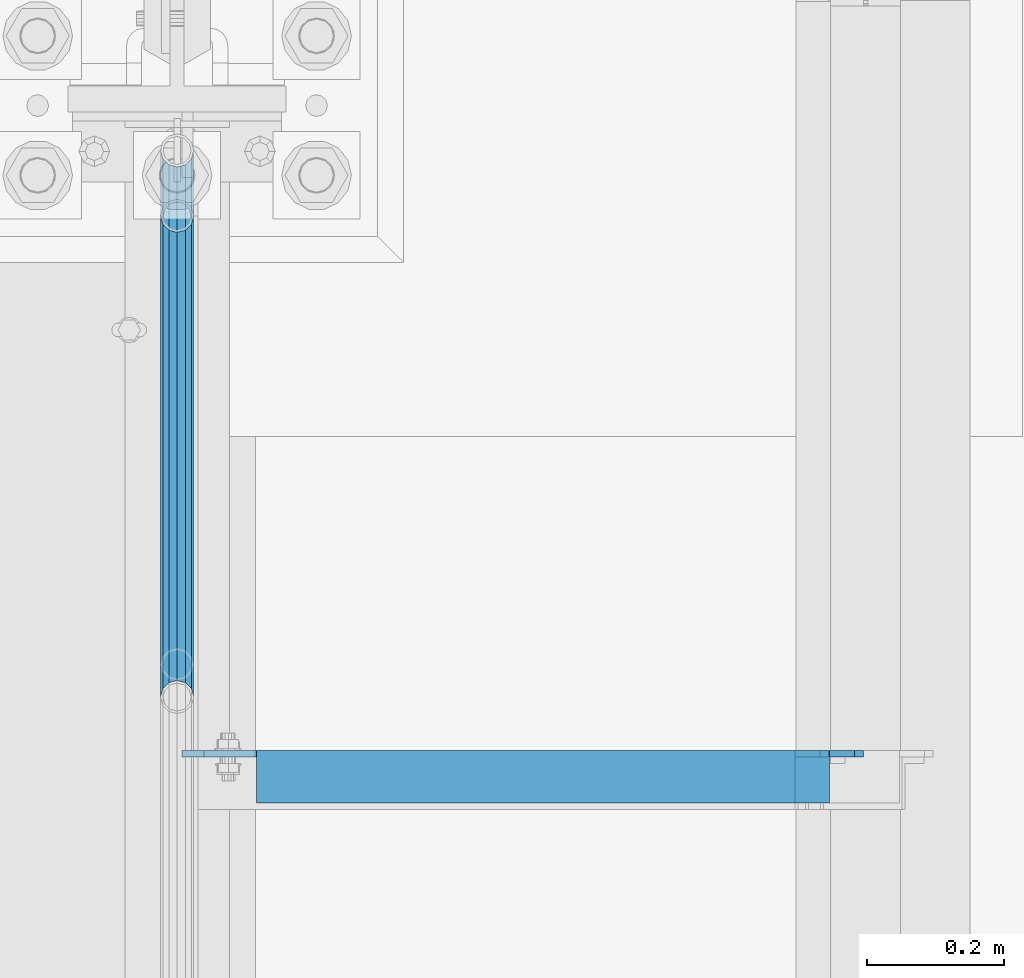
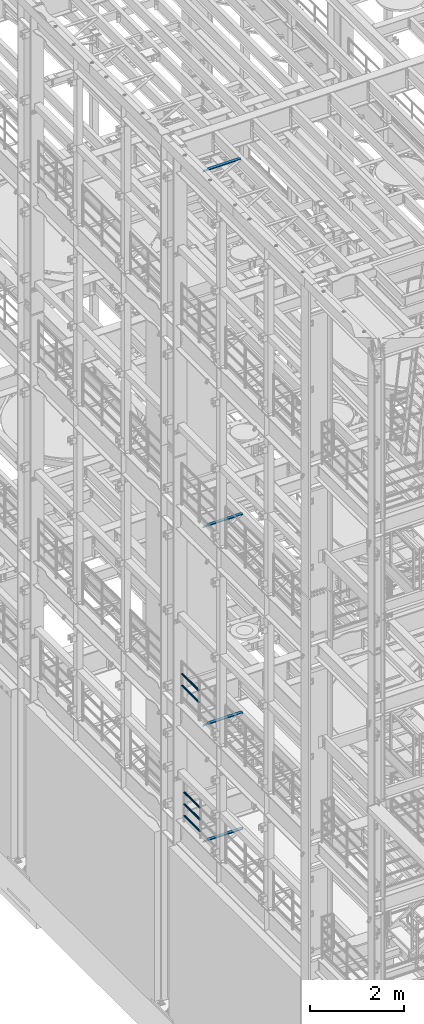
# One storey, part 1234 of 1876: 9 beams, 6 elements without a shape of their own.
"""IFC2X3 building model written with IfcOpenShell, lengths in millimetres."""

from ifc_helpers import new_model, si_unit, frame, origin_with_axes, place, context, subcontext, project, spatial, faceted_brep, material, type_object, element, aggregate, save


model = new_model("IFC2X3")

# Units and contexts
model_context = context("Model", 3, precision=1e-05, world=origin_with_axes())
body_context = subcontext(model_context, "Body", "Model", "MODEL_VIEW")
ifc_project = project(units=[si_unit("LENGTHUNIT", "METRE", prefix="MILLI"), si_unit("AREAUNIT", "SQUARE_METRE"), si_unit("VOLUMEUNIT", "CUBIC_METRE"), si_unit("MASSUNIT", "GRAM", prefix="KILO"), si_unit("TIMEUNIT", "SECOND"), si_unit("PLANEANGLEUNIT", "RADIAN"), si_unit("SOLIDANGLEUNIT", "STERADIAN"), si_unit("THERMODYNAMICTEMPERATUREUNIT", "DEGREE_CELSIUS"), si_unit("LUMINOUSINTENSITYUNIT", "LUMEN")], contexts=[model_context])

# Site, building, storey
site_placement = place(None, origin_with_axes())
site = spatial("IfcSite", under=ifc_project, at=site_placement, CompositionType="ELEMENT")
building_placement = place(site_placement, origin_with_axes())
building = spatial("IfcBuilding", under=site, at=building_placement, Name="Undefined", CompositionType="ELEMENT")
storey_placement = place(building_placement, origin_with_axes())
storey = spatial("IfcBuildingStorey", under=building, at=storey_placement, Name="Undefined", CompositionType="ELEMENT", Elevation=0.0)

# Assembly, beams
assembly_1_placement = place(storey_placement, origin_with_axes())
assembly_1 = element("IfcElementAssembly", 1, at=assembly_1_placement, inside=storey, Name="RAIL", AssemblyPlace="NOTDEFINED", PredefinedType="RIGID_FRAME")
ifc_material_1 = material()
beam_type_1 = type_object("IfcBeamType", Name="PIPE1-1/2SCH40", PredefinedType="NOTDEFINED")
beam_1_placement = place(assembly_1_placement, frame((-1.81898940354586e-12, 430.212499999999, 8620.125), z_axis=(0.0, 0.0, -1.0), x_axis=(0.0, 1.0, 0.0)))
beam_1 = element("IfcBeam", 2, at=beam_1_placement, type_object=beam_type_1, material=ifc_material_1, Name="RAIL", ObjectType="PIPE1-1/2SCH40", context=body_context, shape_type="Brep", body=[
    faceted_brep([(0.0, 24.1299999999992, 0.0), (12.0650000000064, 20.8971929933177, -12.0649999999987), (12.0650000000064, 20.8971929933177, 12.0649999999987), (12.0650000000064, -20.8971929933177, 12.0649999999987), (12.0650000000064, -20.8971929933177, -12.0649999999987), (0.0, -24.1299999999992, 0.0), (20.8971929933249, -12.0650000000005, 20.8971929933177), (20.8971929933249, -12.0650000000005, 15.8661214311796), (15.2545715621445, -17.7076214311801, 10.2235000000001), (12.5151929933249, -20.4470000000001, 0.0), (15.2545715621445, -17.7076214311801, -10.2235000000001), (20.8971929933249, -12.0650000000005, -15.8661214311796), (20.8971929933249, -12.0650000000005, -20.8971929933177), (24.1300000000063, 0.0, -20.4470000000001), (24.1300000000063, 0.0, -24.130000000001), (21.3906214311868, -10.2235000000001, -17.7076214311819), (21.3906214311868, 10.2235000000001, -17.7076214311819), (20.8971929933249, 12.0650000000005, -15.8661214311796), (20.8971929933249, 12.0650000000005, -20.8971929933177), (15.2545715621445, 17.7076214311801, -10.2235000000001), (12.5151929933249, 20.4470000000001, 0.0), (15.2545715621445, 17.7076214311801, 10.2235000000001), (20.8971929933249, 12.0650000000005, 15.8661214311796), (20.8971929933249, 12.0650000000005, 20.8971929933177), (21.3906214311868, 10.2235000000001, 17.7076214311819), (24.1300000000064, 0.0, 20.4470000000001), (24.1300000000064, 0.0, 24.130000000001), (21.3906214311868, -10.2235000000001, 17.7076214311819), (748.982500000002, 24.1300000000001, 0.0), (736.917500000002, 20.8971929933186, -12.0649999999987), (728.085307006683, 12.0649999999996, -20.8971929933177), (748.982500000002, -24.1300000000001, 0.0), (736.917500000002, -20.8971929933186, -12.0649999999987), (736.917500000002, -20.8971929933186, 12.0649999999987), (728.085307006683, -12.0649999999996, 20.8971929933177), (728.085307006683, -12.0649999999996, -20.8971929933177), (724.852500000002, 0.0, -24.130000000001), (727.591878568821, 10.2235000000001, -17.7076214311819), (724.852500000002, 0.0, -20.4470000000001), (728.085307006683, 12.0649999999996, -15.8661214311796), (728.085307006683, -12.0649999999996, -15.8661214311796), (727.591878568821, -10.2235000000001, -17.7076214311819), (733.727928437864, -17.7076214311801, -10.2235000000001), (736.467307006683, -20.4470000000001, 0.0), (733.727928437864, -17.7076214311801, 10.2235000000001), (728.085307006683, -12.0649999999996, 15.8661214311796), (727.591878568821, -10.2235000000001, 17.7076214311819), (724.852500000002, 0.0, 20.4470000000001), (724.852500000002, 0.0, 24.130000000001), (728.085307006683, 12.0649999999996, 20.8971929933177), (736.917500000002, 20.8971929933186, 12.0649999999987), (728.085307006683, 12.0649999999996, 15.8661214311796), (733.727928437864, 17.7076214311801, 10.2235000000001), (736.467307006683, 20.4470000000001, 0.0), (733.727928437864, 17.7076214311801, -10.2235000000001), (727.591878568821, 10.2235000000001, 17.7076214311819)], [[[0, 1, 2]], [[3, 4, 5]], [[6, 7, 8, 9, 10, 11, 12, 4, 3]], [[13, 14, 12, 11, 15]], [[16, 17, 18, 14, 13]], [[2, 1, 18, 17, 19, 20, 21, 22, 23]], [[23, 22, 24, 25, 26]], [[26, 25, 27, 7, 6]], [[1, 0, 28, 29]], [[18, 1, 29, 30]], [[31, 32, 33]], [[6, 3, 33, 34]], [[3, 5, 31, 33]], [[5, 4, 32, 31]], [[4, 12, 35, 32]], [[12, 14, 36, 35]], [[14, 18, 30, 36]], [[37, 38, 36, 30, 39]], [[40, 35, 36, 38, 41]], [[33, 32, 35, 40, 42, 43, 44, 45, 34]], [[34, 45, 46, 47, 48]], [[26, 6, 34, 48]], [[2, 23, 49, 50]], [[23, 26, 48, 49]], [[0, 2, 50, 28]], [[28, 50, 29]], [[49, 51, 52, 53, 54, 39, 30, 29, 50]], [[48, 47, 55, 51, 49]], [[25, 24, 55, 47]], [[55, 24, 22, 21, 52, 51]], [[21, 20, 53, 52]], [[20, 19, 54, 53]], [[19, 17, 16, 37, 39, 54]], [[16, 13, 38, 37]], [[13, 15, 41, 38]], [[41, 15, 11, 10, 42, 40]], [[10, 9, 43, 42]], [[9, 8, 44, 43]], [[8, 7, 27, 46, 45, 44]], [[27, 25, 47, 46]]]),
])
beam_2_placement = place(assembly_1_placement, frame((-1.81898940354586e-12, 430.212499999999, 8924.925), z_axis=(0.0, 0.0, -1.0), x_axis=(0.0, 1.0, 0.0)))
beam_2 = element("IfcBeam", 3, at=beam_2_placement, type_object=beam_type_1, material=ifc_material_1, Name="RAIL", ObjectType="PIPE1-1/2SCH40", context=body_context, shape_type="Brep", body=[
    faceted_brep([(0.0, 24.1299999999992, 0.0), (12.0650000000064, 20.8971929933177, -12.0649999999987), (12.0650000000064, 20.8971929933177, 12.0649999999987), (12.0650000000064, -20.8971929933177, 12.0649999999987), (12.0650000000064, -20.8971929933177, -12.0649999999987), (0.0, -24.1299999999992, 0.0), (20.8971929933249, -12.0650000000005, 20.8971929933177), (20.8971929933249, -12.0650000000005, 15.8661214311796), (15.2545715621445, -17.7076214311801, 10.2235000000001), (12.5151929933249, -20.4470000000001, 0.0), (15.2545715621445, -17.7076214311801, -10.2235000000001), (20.8971929933249, -12.0650000000005, -15.8661214311796), (20.8971929933249, -12.0650000000005, -20.8971929933177), (24.1300000000063, 0.0, -20.4470000000001), (24.1300000000063, 0.0, -24.130000000001), (21.3906214311868, -10.2235000000001, -17.7076214311819), (21.3906214311868, 10.2235000000001, -17.7076214311819), (20.8971929933249, 12.0650000000005, -15.8661214311796), (20.8971929933249, 12.0650000000005, -20.8971929933177), (15.2545715621445, 17.7076214311801, -10.2235000000001), (12.5151929933249, 20.4470000000001, 0.0), (15.2545715621445, 17.7076214311801, 10.2235000000001), (20.8971929933249, 12.0650000000005, 15.8661214311796), (20.8971929933249, 12.0650000000005, 20.8971929933177), (21.3906214311868, 10.2235000000001, 17.7076214311819), (24.1300000000064, 0.0, 20.4470000000001), (24.1300000000064, 0.0, 24.130000000001), (21.3906214311868, -10.2235000000001, 17.7076214311819), (748.982500000002, 24.1300000000001, 0.0), (736.917500000002, 20.8971929933186, -12.0649999999987), (728.085307006683, 12.0649999999996, -20.8971929933177), (748.982500000002, -24.1300000000001, 0.0), (736.917500000002, -20.8971929933186, -12.0649999999987), (736.917500000002, -20.8971929933186, 12.0649999999987), (728.085307006683, -12.0649999999996, 20.8971929933177), (728.085307006683, -12.0649999999996, -20.8971929933177), (724.852500000002, 0.0, -24.130000000001), (727.591878568821, 10.2235000000001, -17.7076214311819), (724.852500000002, 0.0, -20.4470000000001), (728.085307006683, 12.0649999999996, -15.8661214311796), (728.085307006683, -12.0649999999996, -15.8661214311796), (727.591878568821, -10.2235000000001, -17.7076214311819), (733.727928437864, -17.7076214311801, -10.2235000000001), (736.467307006683, -20.4470000000001, 0.0), (733.727928437864, -17.7076214311801, 10.2235000000001), (728.085307006683, -12.0649999999996, 15.8661214311796), (727.591878568821, -10.2235000000001, 17.7076214311819), (724.852500000002, 0.0, 20.4470000000001), (724.852500000002, 0.0, 24.130000000001), (728.085307006683, 12.0649999999996, 20.8971929933177), (736.917500000002, 20.8971929933186, 12.0649999999987), (728.085307006683, 12.0649999999996, 15.8661214311796), (733.727928437864, 17.7076214311801, 10.2235000000001), (736.467307006683, 20.4470000000001, 0.0), (733.727928437864, 17.7076214311801, -10.2235000000001), (727.591878568821, 10.2235000000001, 17.7076214311819)], [[[0, 1, 2]], [[3, 4, 5]], [[6, 7, 8, 9, 10, 11, 12, 4, 3]], [[13, 14, 12, 11, 15]], [[16, 17, 18, 14, 13]], [[2, 1, 18, 17, 19, 20, 21, 22, 23]], [[23, 22, 24, 25, 26]], [[26, 25, 27, 7, 6]], [[1, 0, 28, 29]], [[18, 1, 29, 30]], [[31, 32, 33]], [[6, 3, 33, 34]], [[3, 5, 31, 33]], [[5, 4, 32, 31]], [[4, 12, 35, 32]], [[12, 14, 36, 35]], [[14, 18, 30, 36]], [[37, 38, 36, 30, 39]], [[40, 35, 36, 38, 41]], [[33, 32, 35, 40, 42, 43, 44, 45, 34]], [[34, 45, 46, 47, 48]], [[26, 6, 34, 48]], [[2, 23, 49, 50]], [[23, 26, 48, 49]], [[0, 2, 50, 28]], [[28, 50, 29]], [[49, 51, 52, 53, 54, 39, 30, 29, 50]], [[48, 47, 55, 51, 49]], [[25, 24, 55, 47]], [[55, 24, 22, 21, 52, 51]], [[21, 20, 53, 52]], [[20, 19, 54, 53]], [[19, 17, 16, 37, 39, 54]], [[16, 13, 38, 37]], [[13, 15, 41, 38]], [[41, 15, 11, 10, 42, 40]], [[10, 9, 43, 42]], [[9, 8, 44, 43]], [[8, 7, 27, 46, 45, 44]], [[27, 25, 47, 46]]]),
])
aggregate(assembly_1, [beam_1, beam_2])

assembly_2_placement = place(storey_placement, origin_with_axes())
assembly_2 = element("IfcElementAssembly", 4, at=assembly_2_placement, inside=storey, Name="RAIL", AssemblyPlace="NOTDEFINED", PredefinedType="RIGID_FRAME")
beam_3_placement = place(assembly_2_placement, frame((7.02584657119587e-11, 382.569831680701, 5292.73091229414), z_axis=(0.0, -8.42999999986204e-06, 0.999999999964468), x_axis=(0.0, 0.999999999964468, 8.43000000018809e-06)))
beam_3 = element("IfcBeam", 5, at=beam_3_placement, type_object=beam_type_1, material=ifc_material_1, Name="RAIL", ObjectType="PIPE1-1/2SCH40", context=body_context, shape_type="Brep", body=[
    faceted_brep([(680.442814874983, -12.0649999999996, 20.8971929933068), (680.44277246305, -12.0649999999277, 15.8661214312397), (679.949359549034, -10.2235000000001, 17.7076214311674), (677.210004073059, 2.72848410531878e-12, 20.4469999999883), (677.210035120749, 2.72848410531878e-12, 24.1299999999883), (679.949359548996, 10.2235000000001, 17.7076214311674), (680.44277246305, 12.0650000000714, 15.866121431096), (680.442814874983, 12.0649999999996, 20.8971929933068), (701.33983170571, 24.1300000000001, -1.45519152283669e-11), (689.27493341323, 20.8971929933186, 12.0649999999878), (689.27472999733, 20.8971929933186, -12.0650000000151), (686.085346327061, 17.7076214311801, 10.2234999999873), (688.824638711873, 20.4470000000001, -1.36424205265939e-11), (686.085173958852, 17.7076214311801, -10.2235000000137), (680.442504960242, 12.0650000000714, -15.8661214311223), (680.442462548309, 12.0649999999996, -20.8971929933323), (679.949060998498, 10.2235000000001, -17.7076214311946), (677.20965933664, 0.0, -20.4470000000147), (677.20962828895, 0.0, -24.1300000000147), (680.442504960242, -12.0649999999277, -15.866121431266), (680.442462548309, -12.0649999999996, -20.8971929933323), (679.949060998536, -10.2235000000001, -17.7076214311946), (701.33983170571, -24.1299999999283, -1.45519152283669e-11), (689.27472999733, -20.8971929933186, -12.0650000000151), (689.27493341323, -20.8971929933186, 12.0649999999878), (686.085173958994, -17.7076214311801, -10.2235000000137), (688.824638712016, -20.4470000000001, -1.36424205265939e-11), (686.085346327204, -17.7076214311801, 10.2234999999873), (12.0648982924813, -20.8971929933186, -12.0650000000005), (20.8970168307269, -12.0649999999996, -20.8971929933195), (0.0, 24.1299999999992, 0.0), (12.0648982924813, 20.8971929933186, -12.0650000000005), (12.065101708381, 20.8971929933186, 12.0650000000005), (20.897369157401, 12.0649999999996, 20.8971929933205), (24.1302034167611, 7.18500814400613e-11, 24.1300000000019), (20.8970168307269, 12.0649999999996, -20.8971929933195), (24.1297965849608, 0.0, -24.130000000001), (24.1298276326506, 0.0, -20.447000000001), (20.8970592426604, -12.0649999999277, -15.8661214312533), (21.390472156676, -10.2235000000001, -17.7076214311819), (21.3904721567151, 10.2235000000001, -17.7076214311819), (20.8970592426604, 12.0650000000714, -15.8661214311096), (15.2544853786503, 17.7076214311801, -10.2235000000001), (12.5151929933249, 20.4470000000001, 0.0), (15.2546577468602, 17.7076214311801, 10.223500000001), (20.8973267454676, 12.0650000000714, 15.8661214311096), (21.3907707072121, 10.2235000000001, 17.7076214311819), (24.1301723690713, 7.18500814400613e-11, 20.447000000001), (21.390770707173, -10.2235000000001, 17.7076214311819), (20.8973267454676, -12.0649999999277, 15.8661214312533), (20.897369157401, -12.0649999999996, 20.8971929933205), (12.065101708381, -20.8971929933186, 12.0650000000005), (0.0, -24.1299999999992, 0.0), (15.2546577467156, -17.7076214311801, 10.223500000001), (12.5151929933249, -20.4470000000001, 0.0), (15.2544853785057, -17.7076214311801, -10.2235000000001)], [[[0, 1, 2, 3, 4]], [[4, 3, 5, 6, 7]], [[8, 9, 10]], [[7, 6, 11, 12, 13, 14, 15, 10, 9]], [[16, 17, 18, 15, 14]], [[19, 20, 18, 17, 21]], [[22, 23, 24]], [[24, 23, 20, 19, 25, 26, 27, 1, 0]], [[28, 29, 20, 23]], [[30, 31, 32]], [[33, 34, 4, 7]], [[32, 33, 7, 9]], [[30, 32, 9, 8]], [[31, 30, 8, 10]], [[35, 31, 10, 15]], [[36, 35, 15, 18]], [[29, 36, 18, 20]], [[37, 36, 29, 38, 39]], [[40, 41, 35, 36, 37]], [[32, 31, 35, 41, 42, 43, 44, 45, 33]], [[33, 45, 46, 47, 34]], [[34, 47, 48, 49, 50]], [[34, 50, 0, 4]], [[50, 51, 24, 0]], [[51, 52, 22, 24]], [[52, 28, 23, 22]], [[51, 28, 52]], [[50, 49, 53, 54, 55, 38, 29, 28, 51]], [[55, 54, 26, 25]], [[21, 39, 38, 55, 25, 19]], [[37, 39, 21, 17]], [[40, 37, 17, 16]], [[42, 41, 40, 16, 14, 13]], [[43, 42, 13, 12]], [[44, 43, 12, 11]], [[5, 46, 45, 44, 11, 6]], [[47, 46, 5, 3]], [[48, 47, 3, 2]], [[53, 49, 48, 2, 1, 27]], [[54, 53, 27, 26]]]),
])
beam_4_placement = place(assembly_2_placement, frame((3.1513991416432e-10, 1083.9096633614, 5597.53682459919), z_axis=(0.0, 7.91400000045761e-06, -0.999999999968684), x_axis=(0.0, -0.999999999968684, -7.91400000071008e-06)))
beam_4 = element("IfcBeam", 6, at=beam_4_placement, type_object=beam_type_1, material=ifc_material_1, Name="RAIL", ObjectType="PIPE1-1/2SCH40", context=body_context, shape_type="Brep", body=[
    faceted_brep([(0.0, 24.1299999999992, 0.0), (12.0648982924813, 20.8971929933186, -12.0650000000005), (12.065101708381, 20.8971929933186, 12.0650000000005), (12.065101708381, -20.8971929933186, 12.0650000000005), (12.0648982924813, -20.8971929933186, -12.0650000000005), (0.0, -24.1299999999992, 0.0), (20.897369157401, -12.0649999999996, 20.8971929933205), (20.8973267454676, -12.0649999999277, 15.8661214312533), (15.2546577467156, -17.7076214311801, 10.223500000001), (12.5151929933249, -20.4470000000001, 0.0), (15.2544853785057, -17.7076214311801, -10.2235000000001), (20.8970592426604, -12.0649999999277, -15.8661214312533), (20.8970168307269, -12.0649999999996, -20.8971929933195), (24.1298276326506, 0.0, -20.447000000001), (24.1297965849608, 0.0, -24.130000000001), (21.390472156676, -10.2235000000001, -17.7076214311819), (21.3904721567151, 10.2235000000001, -17.7076214311819), (20.8970592426604, 12.0650000000714, -15.8661214311096), (20.8970168307269, 12.0649999999996, -20.8971929933195), (15.2544853786503, 17.7076214311801, -10.2235000000001), (12.5151929933249, 20.4470000000001, 0.0), (15.2546577468602, 17.7076214311801, 10.223500000001), (20.8973267454676, 12.0650000000714, 15.8661214311096), (20.897369157401, 12.0649999999996, 20.8971929933205), (21.3907707072121, 10.2235000000001, 17.7076214311819), (24.1301723690713, 7.18500814400613e-11, 20.447000000001), (24.1302034167611, 7.18500814400613e-11, 24.1300000000019), (21.390770707173, -10.2235000000001, 17.7076214311819), (701.33983170571, 24.1300000000001, -1.45519152283669e-11), (689.27472999733, 20.8971929933186, -12.0650000000151), (680.442462548309, 12.0649999999996, -20.8971929933323), (701.33983170571, -24.1299999999283, -1.45519152283669e-11), (689.27472999733, -20.8971929933186, -12.0650000000151), (689.27493341323, -20.8971929933186, 12.0649999999878), (680.442814874983, -12.0649999999996, 20.8971929933068), (680.442462548309, -12.0649999999996, -20.8971929933323), (677.20962828895, 0.0, -24.1300000000147), (679.949060998498, 10.2235000000001, -17.7076214311946), (677.20965933664, 0.0, -20.4470000000147), (680.442504960242, 12.0650000000714, -15.8661214311223), (680.442504960242, -12.0649999999277, -15.866121431266), (679.949060998536, -10.2235000000001, -17.7076214311946), (686.085173958994, -17.7076214311801, -10.2235000000137), (688.824638712016, -20.4470000000001, -1.36424205265939e-11), (686.085346327204, -17.7076214311801, 10.2234999999873), (680.44277246305, -12.0649999999277, 15.8661214312397), (679.949359549034, -10.2235000000001, 17.7076214311674), (677.210004073059, 2.72848410531878e-12, 20.4469999999883), (677.210035120749, 2.72848410531878e-12, 24.1299999999883), (680.442814874983, 12.0649999999996, 20.8971929933068), (689.27493341323, 20.8971929933186, 12.0649999999878), (680.44277246305, 12.0650000000714, 15.866121431096), (686.085346327061, 17.7076214311801, 10.2234999999873), (688.824638711873, 20.4470000000001, -1.36424205265939e-11), (686.085173958852, 17.7076214311801, -10.2235000000137), (679.949359548996, 10.2235000000001, 17.7076214311674)], [[[0, 1, 2]], [[3, 4, 5]], [[6, 7, 8, 9, 10, 11, 12, 4, 3]], [[13, 14, 12, 11, 15]], [[16, 17, 18, 14, 13]], [[2, 1, 18, 17, 19, 20, 21, 22, 23]], [[23, 22, 24, 25, 26]], [[26, 25, 27, 7, 6]], [[1, 0, 28, 29]], [[18, 1, 29, 30]], [[31, 32, 33]], [[6, 3, 33, 34]], [[3, 5, 31, 33]], [[5, 4, 32, 31]], [[4, 12, 35, 32]], [[12, 14, 36, 35]], [[14, 18, 30, 36]], [[37, 38, 36, 30, 39]], [[40, 35, 36, 38, 41]], [[33, 32, 35, 40, 42, 43, 44, 45, 34]], [[34, 45, 46, 47, 48]], [[26, 6, 34, 48]], [[2, 23, 49, 50]], [[23, 26, 48, 49]], [[0, 2, 50, 28]], [[28, 50, 29]], [[49, 51, 52, 53, 54, 39, 30, 29, 50]], [[48, 47, 55, 51, 49]], [[25, 24, 55, 47]], [[55, 24, 22, 21, 52, 51]], [[21, 20, 53, 52]], [[20, 19, 54, 53]], [[19, 17, 16, 37, 39, 54]], [[16, 13, 38, 37]], [[13, 15, 41, 38]], [[41, 15, 11, 10, 42, 40]], [[10, 9, 43, 42]], [[9, 8, 44, 43]], [[8, 7, 27, 46, 45, 44]], [[27, 25, 47, 46]]]),
])
beam_5_placement = place(assembly_2_placement, frame((6.68023858452216e-10, 1083.9096633614, 5902.3368245991), z_axis=(0.0, 7.91400000045761e-06, -0.999999999968684), x_axis=(0.0, -0.999999999968684, -7.91400000071008e-06)))
beam_5 = element("IfcBeam", 7, at=beam_5_placement, type_object=beam_type_1, material=ifc_material_1, Name="RAIL", ObjectType="PIPE1-1/2SCH40", context=body_context, shape_type="Brep", body=[
    faceted_brep([(0.0, 24.1299999999992, 0.0), (12.0648982924813, 20.8971929933186, -12.0650000000005), (12.065101708381, 20.8971929933186, 12.0650000000005), (12.065101708381, -20.8971929933186, 12.0650000000005), (12.0648982924813, -20.8971929933186, -12.0650000000005), (0.0, -24.1299999999992, 0.0), (20.897369157401, -12.0649999999996, 20.8971929933205), (20.8973267454676, -12.0649999999277, 15.8661214312533), (15.2546577467156, -17.7076214311801, 10.223500000001), (12.5151929933249, -20.4470000000001, 0.0), (15.2544853785057, -17.7076214311801, -10.2235000000001), (20.8970592426604, -12.0649999999277, -15.8661214312533), (20.8970168307269, -12.0649999999996, -20.8971929933195), (24.1298276326506, 0.0, -20.447000000001), (24.1297965849608, 0.0, -24.130000000001), (21.390472156676, -10.2235000000001, -17.7076214311819), (21.3904721567151, 10.2235000000001, -17.7076214311819), (20.8970592426604, 12.0650000000714, -15.8661214311096), (20.8970168307269, 12.0649999999996, -20.8971929933195), (15.2544853786503, 17.7076214311801, -10.2235000000001), (12.5151929933249, 20.4470000000001, 0.0), (15.2546577468602, 17.7076214311801, 10.223500000001), (20.8973267454676, 12.0650000000714, 15.8661214311096), (20.897369157401, 12.0649999999996, 20.8971929933205), (21.3907707072121, 10.2235000000001, 17.7076214311819), (24.1301723690713, 7.18500814400613e-11, 20.447000000001), (24.1302034167611, 7.18500814400613e-11, 24.1300000000019), (21.390770707173, -10.2235000000001, 17.7076214311819), (701.33983170571, 24.1300000000001, -1.45519152283669e-11), (689.27472999733, 20.8971929933186, -12.0650000000151), (680.442462548309, 12.0649999999996, -20.8971929933323), (701.33983170571, -24.1299999999283, -1.45519152283669e-11), (689.27472999733, -20.8971929933186, -12.0650000000151), (689.27493341323, -20.8971929933186, 12.0649999999878), (680.442814874983, -12.0649999999996, 20.8971929933068), (680.442462548309, -12.0649999999996, -20.8971929933323), (677.20962828895, 0.0, -24.1300000000147), (679.949060998498, 10.2235000000001, -17.7076214311946), (677.20965933664, 0.0, -20.4470000000147), (680.442504960242, 12.0650000000714, -15.8661214311223), (680.442504960242, -12.0649999999277, -15.866121431266), (679.949060998536, -10.2235000000001, -17.7076214311946), (686.085173958994, -17.7076214311801, -10.2235000000137), (688.824638712016, -20.4470000000001, -1.36424205265939e-11), (686.085346327204, -17.7076214311801, 10.2234999999873), (680.44277246305, -12.0649999999277, 15.8661214312397), (679.949359549034, -10.2235000000001, 17.7076214311674), (677.210004073059, 2.72848410531878e-12, 20.4469999999883), (677.210035120749, 2.72848410531878e-12, 24.1299999999883), (680.442814874983, 12.0649999999996, 20.8971929933068), (689.27493341323, 20.8971929933186, 12.0649999999878), (680.44277246305, 12.0650000000714, 15.866121431096), (686.085346327061, 17.7076214311801, 10.2234999999873), (688.824638711873, 20.4470000000001, -1.36424205265939e-11), (686.085173958852, 17.7076214311801, -10.2235000000137), (679.949359548996, 10.2235000000001, 17.7076214311674)], [[[0, 1, 2]], [[3, 4, 5]], [[6, 7, 8, 9, 10, 11, 12, 4, 3]], [[13, 14, 12, 11, 15]], [[16, 17, 18, 14, 13]], [[2, 1, 18, 17, 19, 20, 21, 22, 23]], [[23, 22, 24, 25, 26]], [[26, 25, 27, 7, 6]], [[1, 0, 28, 29]], [[18, 1, 29, 30]], [[31, 32, 33]], [[6, 3, 33, 34]], [[3, 5, 31, 33]], [[5, 4, 32, 31]], [[4, 12, 35, 32]], [[12, 14, 36, 35]], [[14, 18, 30, 36]], [[37, 38, 36, 30, 39]], [[40, 35, 36, 38, 41]], [[33, 32, 35, 40, 42, 43, 44, 45, 34]], [[34, 45, 46, 47, 48]], [[26, 6, 34, 48]], [[2, 23, 49, 50]], [[23, 26, 48, 49]], [[0, 2, 50, 28]], [[28, 50, 29]], [[49, 51, 52, 53, 54, 39, 30, 29, 50]], [[48, 47, 55, 51, 49]], [[25, 24, 55, 47]], [[55, 24, 22, 21, 52, 51]], [[21, 20, 53, 52]], [[20, 19, 54, 53]], [[19, 17, 16, 37, 39, 54]], [[16, 13, 38, 37]], [[13, 15, 41, 38]], [[41, 15, 11, 10, 42, 40]], [[10, 9, 43, 42]], [[9, 8, 44, 43]], [[8, 7, 27, 46, 45, 44]], [[27, 25, 47, 46]]]),
])
aggregate(assembly_2, [beam_3, beam_4, beam_5])

# Assembly, beam
assembly_3_placement = place(storey_placement, origin_with_axes())
assembly_3 = element("IfcElementAssembly", 8, at=assembly_3_placement, inside=storey, Name="ANGLE", AssemblyPlace="NOTDEFINED", PredefinedType="RIGID_FRAME")
ifc_material_2 = material(Name="STEEL/A36")
beam_type_2 = type_object("IfcBeamType", Name="L3X3X3/8", PredefinedType="NOTDEFINED")
beam_6_placement = place(assembly_3_placement, frame((4.51516825708356e-09, 266.699999999997, 22517.1), z_axis=(0.0, -1.0, 0.0), x_axis=(1.0, 0.0, 0.0)))
beam_6 = element("IfcBeam", 9, at=beam_6_placement, type_object=beam_type_2, material=ifc_material_2, Name="ANGLE", ObjectType="L3X3X3/8", context=body_context, shape_type="Brep", body=[
    faceted_brep([(115.886999817316, 28.5750000000007, 38.0999999999999), (115.886999817316, 38.0999999999985, 38.0999999999999), (115.886998826692, 38.0999999999985, -38.0999999999999), (115.88699882669, 12.699999237062, -38.0999999999999), (115.886998950515, 12.699999237062, -28.5749999999998), (115.88699895052, 28.5750000000007, -28.5749999999998), (38.8937432114558, 12.699999237062, -38.0999999999999), (38.8937433352807, 12.699999237062, -28.5749999999998), (7.14374321145577, -19.050000762938, -38.0999999999999), (7.14374333528067, -19.050000762938, -28.5749999999998), (7.1437499954859, -38.0999999999985, -38.0999999999999), (7.1437499954859, -38.0999999999985, -28.5749999999998), (949.325002419604, 15.8750003814712, -28.5749999999998), (936.625002610339, 28.5750000000007, -28.5749999999998), (900.113000619098, 28.5750000000007, -28.5749999999998), (949.324999995485, -38.0999999999985, -28.5749999999998), (949.325002419604, 3.17500152588036, -28.5749999999998), (900.11300241932, 28.5750000000007, 38.0999999999999), (900.1130024193, 38.0999999999985, 38.0999999999999), (900.113000361957, 38.0999999999985, -38.0999999999999), (900.113000361924, 28.5750001907363, -38.0999999999999), (936.625002353164, 28.5750001907363, -38.0999999999999), (949.325002162429, 15.8750003814712, -38.0999999999999), (949.325002162429, 3.17500152588036, -38.0999999999999), (949.324999995485, -38.0999999999985, -38.0999999999999)], [[[0, 1, 2, 3, 4, 5]], [[4, 3, 6, 7]], [[7, 6, 8, 9]], [[8, 10, 11, 9]], [[12, 13, 14, 5, 4, 7, 9, 11, 15, 16]], [[0, 5, 14, 17]], [[1, 0, 17, 18]], [[2, 1, 18, 19]], [[17, 14, 20, 19, 18]], [[13, 21, 20, 14]], [[12, 22, 21, 13]], [[16, 23, 22, 12]], [[10, 8, 6, 3, 2, 19, 20, 21, 22, 23, 24]], [[11, 10, 24, 15]], [[23, 16, 15, 24]]]),
])
aggregate(assembly_3, [beam_6])

assembly_4_placement = place(storey_placement, origin_with_axes())
assembly_4 = element("IfcElementAssembly", 10, at=assembly_4_placement, inside=storey, Name="ANGLE", AssemblyPlace="NOTDEFINED", PredefinedType="RIGID_FRAME")
beam_7_placement = place(assembly_4_placement, frame((0.0, 266.699999999999, 8115.3), z_axis=(0.0, -1.0, 0.0), x_axis=(1.0, 0.0, 0.0)))
beam_7 = element("IfcBeam", 11, at=beam_7_placement, type_object=beam_type_2, material=ifc_material_2, Name="ANGLE", ObjectType="L3X3X3/8", context=body_context, shape_type="Brep", body=[
    faceted_brep([(115.886999817316, 28.5750000000007, 38.0999999999999), (115.886999817316, 38.0999999999985, 38.0999999999999), (115.886998826692, 38.0999999999985, -38.0999999999999), (115.88699882669, 12.699999237062, -38.0999999999999), (115.886998950515, 12.699999237062, -28.5749999999998), (115.88699895052, 28.5750000000007, -28.5749999999998), (38.8937432114558, 12.699999237062, -38.0999999999999), (38.8937433352807, 12.699999237062, -28.5749999999998), (7.14374321145577, -19.050000762938, -38.0999999999999), (7.14374333528067, -19.050000762938, -28.5749999999998), (7.1437499954859, -38.0999999999985, -38.0999999999999), (7.1437499954859, -38.0999999999985, -28.5749999999998), (1000.12500242412, 15.8750003814712, -28.5749999999998), (987.425002614851, 28.5749999999998, -28.5749999999998), (950.913000303442, 28.5749999999998, -28.5749999999998), (1000.12500001551, -38.1000000000004, -28.5749999999998), (1000.12500242412, 3.17500152588036, -28.5749999999998), (950.913001170238, 28.5749999999998, 38.0999999999999), (950.913001170238, 38.1000000000004, 38.0999999999999), (950.913000179614, 38.1000000000004, -38.0999999999999), (950.913000366403, 28.5750001907363, -38.0999999999999), (987.425002357675, 28.5750001907363, -38.0999999999999), (1000.12500216694, 15.8750003814712, -38.0999999999999), (1000.12500216694, 3.17500152588036, -38.0999999999999), (1000.12500001551, -38.1000000000004, -38.0999999999999)], [[[0, 1, 2, 3, 4, 5]], [[4, 3, 6, 7]], [[7, 6, 8, 9]], [[8, 10, 11, 9]], [[12, 13, 14, 5, 4, 7, 9, 11, 15, 16]], [[0, 5, 14, 17]], [[1, 0, 17, 18]], [[2, 1, 18, 19]], [[17, 14, 20, 19, 18]], [[13, 21, 20, 14]], [[12, 22, 21, 13]], [[16, 23, 22, 12]], [[10, 8, 6, 3, 2, 19, 20, 21, 22, 23, 24]], [[11, 10, 24, 15]], [[23, 16, 15, 24]]]),
])
aggregate(assembly_4, [beam_7])

assembly_5_placement = place(storey_placement, origin_with_axes())
assembly_5 = element("IfcElementAssembly", 12, at=assembly_5_placement, inside=storey, Name="ANGLE", AssemblyPlace="NOTDEFINED", PredefinedType="RIGID_FRAME")
beam_8_placement = place(assembly_5_placement, frame((0.0, 266.699999999999, 5092.7), z_axis=(0.0, -1.0, 0.0), x_axis=(1.0, 0.0, 0.0)))
beam_8 = element("IfcBeam", 13, at=beam_8_placement, type_object=beam_type_2, material=ifc_material_2, Name="ANGLE", ObjectType="L3X3X3/8", context=body_context, shape_type="Brep", body=[
    faceted_brep([(115.886999817316, 28.5750000000007, 38.0999999999999), (115.886999817316, 38.0999999999985, 38.0999999999999), (115.886998826692, 38.0999999999985, -38.0999999999999), (115.88699882669, 12.699999237062, -38.0999999999999), (115.886998950515, 12.699999237062, -28.5749999999998), (115.88699895052, 28.5750000000007, -28.5749999999998), (38.8937432114558, 12.699999237062, -38.0999999999999), (38.8937433352807, 12.699999237062, -28.5749999999998), (7.14374321145577, -19.050000762938, -38.0999999999999), (7.14374333528067, -19.050000762938, -28.5749999999998), (7.1437499954859, -38.0999999999985, -38.0999999999999), (7.1437499954859, -38.0999999999985, -28.5749999999998), (1000.12500242412, 15.8750003814712, -28.5749999999998), (987.425002614851, 28.5749999999998, -28.5749999999998), (950.913000303442, 28.5749999999998, -28.5749999999998), (1000.12500001551, -38.1000000000004, -28.5749999999998), (1000.12500242412, 3.17500152588036, -28.5749999999998), (950.913001170238, 28.5749999999998, 38.0999999999999), (950.913001170238, 38.1000000000004, 38.0999999999999), (950.913000179614, 38.1000000000004, -38.0999999999999), (950.913000366403, 28.5750001907363, -38.0999999999999), (987.425002357675, 28.5750001907363, -38.0999999999999), (1000.12500216694, 15.8750003814712, -38.0999999999999), (1000.12500216694, 3.17500152588036, -38.0999999999999), (1000.12500001551, -38.1000000000004, -38.0999999999999)], [[[0, 1, 2, 3, 4, 5]], [[4, 3, 6, 7]], [[7, 6, 8, 9]], [[8, 10, 11, 9]], [[12, 13, 14, 5, 4, 7, 9, 11, 15, 16]], [[0, 5, 14, 17]], [[1, 0, 17, 18]], [[2, 1, 18, 19]], [[17, 14, 20, 19, 18]], [[13, 21, 20, 14]], [[12, 22, 21, 13]], [[16, 23, 22, 12]], [[10, 8, 6, 3, 2, 19, 20, 21, 22, 23, 24]], [[11, 10, 24, 15]], [[23, 16, 15, 24]]]),
])
aggregate(assembly_5, [beam_8])

assembly_6_placement = place(storey_placement, origin_with_axes())
assembly_6 = element("IfcElementAssembly", 14, at=assembly_6_placement, inside=storey, Name="ANGLE", AssemblyPlace="NOTDEFINED", PredefinedType="RIGID_FRAME")
beam_9_placement = place(assembly_6_placement, frame((-1.53617799634132e-08, 266.700000000001, 13271.5), z_axis=(0.0, -1.0, 0.0), x_axis=(1.0, 0.0, 0.0)))
beam_9 = element("IfcBeam", 15, at=beam_9_placement, type_object=beam_type_2, material=ifc_material_2, Name="ANGLE", ObjectType="L3X3X3/8", context=body_context, shape_type="Brep", body=[
    faceted_brep([(115.886999817316, 28.5750000000007, 38.0999999999999), (115.886999817316, 38.0999999999985, 38.0999999999999), (115.886998826692, 38.0999999999985, -38.0999999999999), (115.88699882669, 12.699999237062, -38.0999999999999), (115.886998950515, 12.699999237062, -28.5749999999998), (115.88699895052, 28.5750000000007, -28.5749999999998), (38.8937432114558, 12.699999237062, -38.0999999999999), (38.8937433352807, 12.699999237062, -28.5749999999998), (7.14374321145577, -19.050000762938, -38.0999999999999), (7.14374333528067, -19.050000762938, -28.5749999999998), (7.1437499954859, -38.0999999999985, -38.0999999999999), (7.1437499954859, -38.0999999999985, -28.5749999999998), (1000.12500243948, 14.2880004882809, -28.5749999999998), (987.425002630213, 26.988000297546, -28.5749999999998), (950.913000638941, 26.988000297546, -28.5749999999998), (950.913000303442, 28.5749999999998, -28.5749999999998), (1000.12500001551, -38.1000000000004, -28.5749999999998), (1000.12500243948, 1.58799972534143, -28.5749999999998), (950.913001170238, 28.5749999999998, 38.0999999999999), (950.913001170238, 38.1000000000004, 38.0999999999999), (950.913000179614, 38.1000000000004, -38.0999999999999), (950.913000381765, 26.988000297546, -38.0999999999999), (987.425002373037, 26.988000297546, -38.0999999999999), (1000.1250021823, 14.2880004882809, -38.0999999999999), (1000.1250021823, 1.58799972534143, -38.0999999999999), (1000.12500001551, -38.1000000000004, -38.0999999999999)], [[[0, 1, 2, 3, 4, 5]], [[4, 3, 6, 7]], [[7, 6, 8, 9]], [[8, 10, 11, 9]], [[12, 13, 14, 15, 5, 4, 7, 9, 11, 16, 17]], [[0, 5, 15, 18]], [[1, 0, 18, 19]], [[2, 1, 19, 20]], [[18, 15, 14, 21, 20, 19]], [[13, 22, 21, 14]], [[12, 23, 22, 13]], [[17, 24, 23, 12]], [[10, 8, 6, 3, 2, 20, 21, 22, 23, 24, 25]], [[11, 10, 25, 16]], [[24, 17, 16, 25]]]),
])
aggregate(assembly_6, [beam_9])

save(model, "model.ifc")
